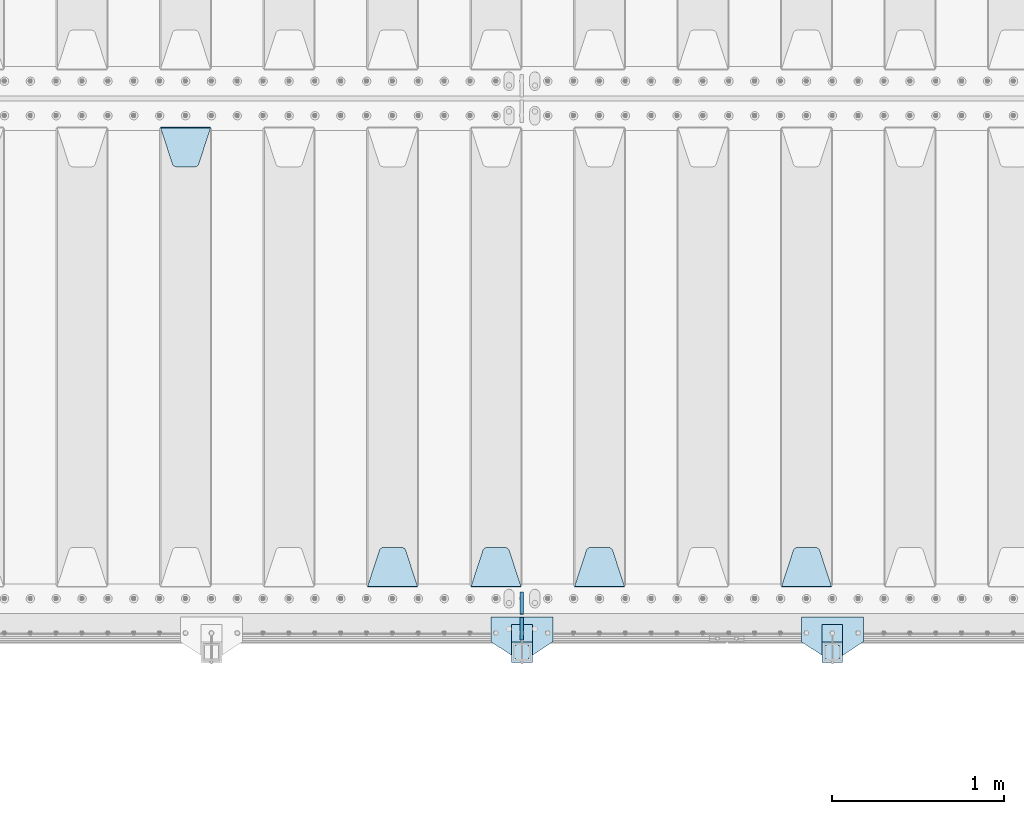
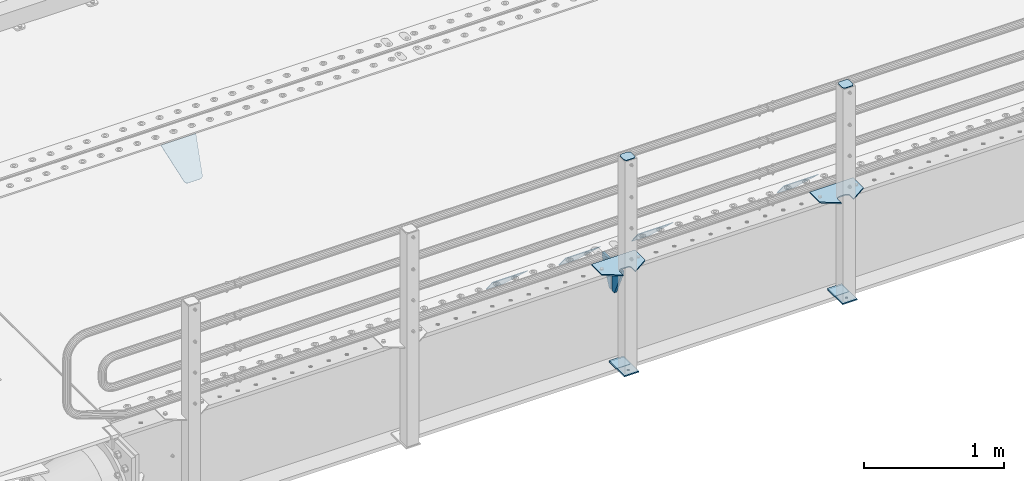
# One storey, part 156 of 193: 15 plates.
"""IFC2X3 building model written with IfcOpenShell, lengths in millimetres."""

from ifc_helpers import new_model, si_unit, frame, origin_with_axes, place, context, subcontext, project, spatial, faceted_brep, material, type_object, element, save


model = new_model("IFC2X3")

# Units and contexts
model_context = context("Model", 3, precision=1e-05, world=origin_with_axes())
body_context = subcontext(model_context, "Body", "Model", "MODEL_VIEW")
ifc_project = project(units=[si_unit("LENGTHUNIT", "METRE", prefix="MILLI"), si_unit("AREAUNIT", "SQUARE_METRE"), si_unit("VOLUMEUNIT", "CUBIC_METRE"), si_unit("MASSUNIT", "GRAM", prefix="KILO"), si_unit("TIMEUNIT", "SECOND"), si_unit("PLANEANGLEUNIT", "RADIAN"), si_unit("SOLIDANGLEUNIT", "STERADIAN"), si_unit("THERMODYNAMICTEMPERATUREUNIT", "DEGREE_CELSIUS"), si_unit("LUMINOUSINTENSITYUNIT", "LUMEN")], contexts=[model_context])

# Site, building, storey
site_placement = place(None, origin_with_axes())
site = spatial("IfcSite", under=ifc_project, at=site_placement, CompositionType="ELEMENT")
building_placement = place(site_placement, origin_with_axes())
building = spatial("IfcBuilding", under=site, at=building_placement, Name="Standard", CompositionType="ELEMENT")
storey_placement = place(building_placement, origin_with_axes())
storey = spatial("IfcBuildingStorey", under=building, at=storey_placement, Name="Undefined", CompositionType="ELEMENT", Elevation=0.0)

# Plates
ifc_material_1 = material(Name="STEEL/S355N")
plate_type_1 = type_object("IfcPlateType", PredefinedType="NOTDEFINED")
plate_1_placement = place(storey_placement, frame((-36505.0, 24168.232233047, -1.76776695296758), z_axis=(0.0, 0.707106781186547, -0.707106781186548), x_axis=(-1.0, 0.0, 0.0)))
element("IfcPlate", 1, at=plate_1_placement, inside=storey, type_object=plate_type_1, material=ifc_material_1, context=body_context, shape_type="Brep", body=[
    faceted_brep([(0.0, -2.5, 0.0), (69.345504679477, -2.50000000000364, 300.171731424831), (69.345504679477, 2.49999999999636, 300.171731424831), (0.0, 2.5, 0.0), (70.9274061199576, -2.50000000000364, 304.897442415397), (70.9274061199576, 2.49999999999636, 304.897442415397), (73.3818627772307, -2.50000000000364, 309.234538108529), (73.3818627772307, 2.49999999999636, 309.234538108529), (76.6187032999551, -2.50000000000728, 313.023683126103), (76.6187032999551, 2.49999999999636, 313.023683126103), (80.5190132704993, -2.50000000000364, 316.125672595372), (80.5190132704993, 2.49999999999636, 316.125672595368), (84.9395038596849, -2.50000000000364, 318.426546230472), (84.9395038596849, 2.49999999999636, 318.426546230476), (89.7177759439219, -2.50000000000364, 319.841774983273), (89.7177759439219, 2.49999999999636, 319.841774983277), (94.678286292652, -2.50000000000364, 320.319366455074), (94.678286292652, 2.49999999999636, 320.319366455074), (195.321713707348, -2.50000000000364, 320.319366455074), (195.321713707348, 2.49999999999636, 320.319366455074), (200.282224056078, -2.50000000000364, 319.841774983273), (200.282224056078, 2.49999999999636, 319.841774983277), (205.060496140315, -2.50000000000364, 318.426546230472), (205.060496140315, 2.49999999999636, 318.426546230472), (209.480986729501, -2.50000000000364, 316.125672595372), (209.480986729501, 2.49999999999636, 316.125672595368), (213.381296700045, -2.50000000000728, 313.023683126103), (213.381296700045, 2.49999999999272, 313.023683126103), (216.618137222769, -2.50000000000364, 309.234538108525), (216.618137222769, 2.49999999999636, 309.234538108522), (219.072593880042, -2.50000000000364, 304.897442415397), (219.072593880042, 2.49999999999636, 304.897442415397), (220.654495320523, -2.50000000000364, 300.171731424831), (220.654495320523, 2.49999999999636, 300.171731424831), (290.0, -2.50000000000364, 0.0), (290.0, 2.49999999999636, 0.0)], [[[0, 1, 2, 3]], [[1, 4, 5, 2]], [[4, 6, 7, 5]], [[6, 8, 9, 7]], [[8, 10, 11, 9]], [[10, 12, 13, 11]], [[12, 14, 15, 13]], [[14, 16, 17, 15]], [[16, 18, 19, 17]], [[18, 20, 21, 19]], [[20, 22, 23, 21]], [[22, 24, 25, 23]], [[24, 26, 27, 25]], [[26, 28, 29, 27]], [[28, 30, 31, 29]], [[30, 32, 33, 31]], [[32, 34, 35, 33]], [[34, 0, 3, 35]], [[5, 7, 9, 11, 13, 15, 17, 19, 21, 23, 25, 27, 29, 31, 33, 35, 3, 2]], [[34, 32, 30, 28, 26, 24, 22, 20, 18, 16, 14, 12, 10, 8, 6, 4, 1, 0]]]),
])
plate_2_placement = place(storey_placement, frame((-37705.0, 24168.232233047, -1.76776695296758), z_axis=(0.0, 0.707106781186547, -0.707106781186548), x_axis=(-1.0, 0.0, 0.0)))
element("IfcPlate", 2, at=plate_2_placement, inside=storey, type_object=plate_type_1, material=ifc_material_1, context=body_context, shape_type="Brep", body=[
    faceted_brep([(0.0, -2.5, 0.0), (69.345504679477, -2.50000000000364, 300.171731424831), (69.345504679477, 2.49999999999636, 300.171731424831), (0.0, 2.5, 0.0), (70.9274061199576, -2.50000000000364, 304.897442415397), (70.9274061199576, 2.49999999999636, 304.897442415397), (73.3818627772307, -2.50000000000364, 309.234538108529), (73.3818627772307, 2.49999999999636, 309.234538108529), (76.6187032999551, -2.50000000000728, 313.023683126103), (76.6187032999551, 2.49999999999636, 313.023683126103), (80.5190132704993, -2.50000000000364, 316.125672595372), (80.5190132704993, 2.49999999999636, 316.125672595368), (84.9395038596849, -2.50000000000364, 318.426546230472), (84.9395038596849, 2.49999999999636, 318.426546230476), (89.7177759439219, -2.50000000000364, 319.841774983273), (89.7177759439219, 2.49999999999636, 319.841774983277), (94.678286292652, -2.50000000000364, 320.319366455074), (94.678286292652, 2.49999999999636, 320.319366455074), (195.321713707348, -2.50000000000364, 320.319366455074), (195.321713707348, 2.49999999999636, 320.319366455074), (200.282224056078, -2.50000000000364, 319.841774983273), (200.282224056078, 2.49999999999636, 319.841774983277), (205.060496140315, -2.50000000000364, 318.426546230472), (205.060496140315, 2.49999999999636, 318.426546230472), (209.480986729501, -2.50000000000364, 316.125672595372), (209.480986729501, 2.49999999999636, 316.125672595368), (213.381296700045, -2.50000000000728, 313.023683126103), (213.381296700045, 2.49999999999272, 313.023683126103), (216.618137222769, -2.50000000000364, 309.234538108525), (216.618137222769, 2.49999999999636, 309.234538108522), (219.072593880042, -2.50000000000364, 304.897442415397), (219.072593880042, 2.49999999999636, 304.897442415397), (220.654495320523, -2.50000000000364, 300.171731424831), (220.654495320523, 2.49999999999636, 300.171731424831), (290.0, -2.50000000000364, 0.0), (290.0, 2.49999999999636, 0.0)], [[[0, 1, 2, 3]], [[1, 4, 5, 2]], [[4, 6, 7, 5]], [[6, 8, 9, 7]], [[8, 10, 11, 9]], [[10, 12, 13, 11]], [[12, 14, 15, 13]], [[14, 16, 17, 15]], [[16, 18, 19, 17]], [[18, 20, 21, 19]], [[20, 22, 23, 21]], [[22, 24, 25, 23]], [[24, 26, 27, 25]], [[26, 28, 29, 27]], [[28, 30, 31, 29]], [[30, 32, 33, 31]], [[32, 34, 35, 33]], [[34, 0, 3, 35]], [[5, 7, 9, 11, 13, 15, 17, 19, 21, 23, 25, 27, 29, 31, 33, 35, 3, 2]], [[34, 32, 30, 28, 26, 24, 22, 20, 18, 16, 14, 12, 10, 8, 6, 4, 1, 0]]]),
])
plate_3_placement = place(storey_placement, frame((-38305.0, 24168.232233047, -1.76776695296758), z_axis=(0.0, 0.707106781186547, -0.707106781186548), x_axis=(-1.0, 0.0, 0.0)))
element("IfcPlate", 3, at=plate_3_placement, inside=storey, type_object=plate_type_1, material=ifc_material_1, context=body_context, shape_type="Brep", body=[
    faceted_brep([(0.0, -2.5, 0.0), (69.345504679477, -2.50000000000364, 300.171731424831), (69.345504679477, 2.49999999999636, 300.171731424831), (0.0, 2.5, 0.0), (70.9274061199576, -2.50000000000364, 304.897442415397), (70.9274061199576, 2.49999999999636, 304.897442415397), (73.3818627772307, -2.50000000000364, 309.234538108529), (73.3818627772307, 2.49999999999636, 309.234538108529), (76.6187032999551, -2.50000000000728, 313.023683126103), (76.6187032999551, 2.49999999999636, 313.023683126103), (80.5190132704993, -2.50000000000364, 316.125672595372), (80.5190132704993, 2.49999999999636, 316.125672595368), (84.9395038596849, -2.50000000000364, 318.426546230472), (84.9395038596849, 2.49999999999636, 318.426546230476), (89.7177759439219, -2.50000000000364, 319.841774983273), (89.7177759439219, 2.49999999999636, 319.841774983277), (94.678286292652, -2.50000000000364, 320.319366455074), (94.678286292652, 2.49999999999636, 320.319366455074), (195.321713707348, -2.50000000000364, 320.319366455074), (195.321713707348, 2.49999999999636, 320.319366455074), (200.282224056078, -2.50000000000364, 319.841774983273), (200.282224056078, 2.49999999999636, 319.841774983277), (205.060496140315, -2.50000000000364, 318.426546230472), (205.060496140315, 2.49999999999636, 318.426546230472), (209.480986729501, -2.50000000000364, 316.125672595372), (209.480986729501, 2.49999999999636, 316.125672595368), (213.381296700045, -2.50000000000728, 313.023683126103), (213.381296700045, 2.49999999999272, 313.023683126103), (216.618137222769, -2.50000000000364, 309.234538108525), (216.618137222769, 2.49999999999636, 309.234538108522), (219.072593880042, -2.50000000000364, 304.897442415397), (219.072593880042, 2.49999999999636, 304.897442415397), (220.654495320523, -2.50000000000364, 300.171731424831), (220.654495320523, 2.49999999999636, 300.171731424831), (290.0, -2.50000000000364, 0.0), (290.0, 2.49999999999636, 0.0)], [[[0, 1, 2, 3]], [[1, 4, 5, 2]], [[4, 6, 7, 5]], [[6, 8, 9, 7]], [[8, 10, 11, 9]], [[10, 12, 13, 11]], [[12, 14, 15, 13]], [[14, 16, 17, 15]], [[16, 18, 19, 17]], [[18, 20, 21, 19]], [[20, 22, 23, 21]], [[22, 24, 25, 23]], [[24, 26, 27, 25]], [[26, 28, 29, 27]], [[28, 30, 31, 29]], [[30, 32, 33, 31]], [[32, 34, 35, 33]], [[34, 0, 3, 35]], [[5, 7, 9, 11, 13, 15, 17, 19, 21, 23, 25, 27, 29, 31, 33, 35, 3, 2]], [[34, 32, 30, 28, 26, 24, 22, 20, 18, 16, 14, 12, 10, 8, 6, 4, 1, 0]]]),
])
plate_4_placement = place(storey_placement, frame((-38905.0, 24168.232233047, -1.76776695296758), z_axis=(0.0, 0.707106781186547, -0.707106781186548), x_axis=(-1.0, 0.0, 0.0)))
element("IfcPlate", 4, at=plate_4_placement, inside=storey, type_object=plate_type_1, material=ifc_material_1, context=body_context, shape_type="Brep", body=[
    faceted_brep([(0.0, -2.5, 0.0), (69.345504679477, -2.50000000000364, 300.171731424831), (69.345504679477, 2.49999999999636, 300.171731424831), (0.0, 2.5, 0.0), (70.9274061199576, -2.50000000000364, 304.897442415397), (70.9274061199576, 2.49999999999636, 304.897442415397), (73.3818627772307, -2.50000000000364, 309.234538108529), (73.3818627772307, 2.49999999999636, 309.234538108529), (76.6187032999551, -2.50000000000728, 313.023683126103), (76.6187032999551, 2.49999999999636, 313.023683126103), (80.5190132704993, -2.50000000000364, 316.125672595372), (80.5190132704993, 2.49999999999636, 316.125672595368), (84.9395038596849, -2.50000000000364, 318.426546230472), (84.9395038596849, 2.49999999999636, 318.426546230476), (89.7177759439219, -2.50000000000364, 319.841774983273), (89.7177759439219, 2.49999999999636, 319.841774983277), (94.678286292652, -2.50000000000364, 320.319366455074), (94.678286292652, 2.49999999999636, 320.319366455074), (195.321713707348, -2.50000000000364, 320.319366455074), (195.321713707348, 2.49999999999636, 320.319366455074), (200.282224056078, -2.50000000000364, 319.841774983273), (200.282224056078, 2.49999999999636, 319.841774983277), (205.060496140315, -2.50000000000364, 318.426546230472), (205.060496140315, 2.49999999999636, 318.426546230472), (209.480986729501, -2.50000000000364, 316.125672595372), (209.480986729501, 2.49999999999636, 316.125672595368), (213.381296700045, -2.50000000000728, 313.023683126103), (213.381296700045, 2.49999999999272, 313.023683126103), (216.618137222769, -2.50000000000364, 309.234538108525), (216.618137222769, 2.49999999999636, 309.234538108522), (219.072593880042, -2.50000000000364, 304.897442415397), (219.072593880042, 2.49999999999636, 304.897442415397), (220.654495320523, -2.50000000000364, 300.171731424831), (220.654495320523, 2.49999999999636, 300.171731424831), (290.0, -2.50000000000364, 0.0), (290.0, 2.49999999999636, 0.0)], [[[0, 1, 2, 3]], [[1, 4, 5, 2]], [[4, 6, 7, 5]], [[6, 8, 9, 7]], [[8, 10, 11, 9]], [[10, 12, 13, 11]], [[12, 14, 15, 13]], [[14, 16, 17, 15]], [[16, 18, 19, 17]], [[18, 20, 21, 19]], [[20, 22, 23, 21]], [[22, 24, 25, 23]], [[24, 26, 27, 25]], [[26, 28, 29, 27]], [[28, 30, 31, 29]], [[30, 32, 33, 31]], [[32, 34, 35, 33]], [[34, 0, 3, 35]], [[5, 7, 9, 11, 13, 15, 17, 19, 21, 23, 25, 27, 29, 31, 33, 35, 3, 2]], [[34, 32, 30, 28, 26, 24, 22, 20, 18, 16, 14, 12, 10, 8, 6, 4, 1, 0]]]),
])
plate_5_placement = place(storey_placement, frame((-40395.0, 26831.767766956, -1.76776695296758), z_axis=(0.0, -0.707106781186547, -0.707106781186548), x_axis=(1.0, 0.0, 0.0)))
element("IfcPlate", 5, at=plate_5_placement, inside=storey, type_object=plate_type_1, material=ifc_material_1, context=body_context, shape_type="Brep", body=[
    faceted_brep([(0.0, -2.5, 0.0), (69.345504679477, -2.50000000000364, 300.171731424831), (69.345504679477, 2.49999999999636, 300.171731424831), (0.0, 2.5, 0.0), (70.9274061199576, -2.50000000000364, 304.897442415397), (70.9274061199576, 2.49999999999636, 304.897442415397), (73.3818627772307, -2.50000000000364, 309.234538108529), (73.3818627772307, 2.49999999999636, 309.234538108529), (76.6187032999551, -2.50000000000728, 313.023683126103), (76.6187032999551, 2.49999999999636, 313.023683126103), (80.5190132704993, -2.50000000000364, 316.125672595372), (80.5190132704993, 2.49999999999636, 316.125672595368), (84.9395038596849, -2.50000000000364, 318.426546230472), (84.9395038596849, 2.49999999999636, 318.426546230476), (89.7177759439219, -2.50000000000364, 319.841774983273), (89.7177759439219, 2.49999999999636, 319.841774983277), (94.678286292652, -2.50000000000364, 320.319366455074), (94.678286292652, 2.49999999999636, 320.319366455074), (195.321713707348, -2.50000000000364, 320.319366455074), (195.321713707348, 2.49999999999636, 320.319366455074), (200.282224056078, -2.50000000000364, 319.841774983273), (200.282224056078, 2.49999999999636, 319.841774983277), (205.060496140315, -2.50000000000364, 318.426546230472), (205.060496140315, 2.49999999999636, 318.426546230472), (209.480986729501, -2.50000000000364, 316.125672595372), (209.480986729501, 2.49999999999636, 316.125672595368), (213.381296700045, -2.50000000000728, 313.023683126103), (213.381296700045, 2.49999999999272, 313.023683126103), (216.618137222769, -2.50000000000364, 309.234538108525), (216.618137222769, 2.49999999999636, 309.234538108522), (219.072593880042, -2.50000000000364, 304.897442415397), (219.072593880042, 2.49999999999636, 304.897442415397), (220.654495320523, -2.50000000000364, 300.171731424831), (220.654495320523, 2.49999999999636, 300.171731424831), (290.0, -2.50000000000364, 0.0), (290.0, 2.49999999999636, 0.0)], [[[0, 1, 2, 3]], [[1, 4, 5, 2]], [[4, 6, 7, 5]], [[6, 8, 9, 7]], [[8, 10, 11, 9]], [[10, 12, 13, 11]], [[12, 14, 15, 13]], [[14, 16, 17, 15]], [[16, 18, 19, 17]], [[18, 20, 21, 19]], [[20, 22, 23, 21]], [[22, 24, 25, 23]], [[24, 26, 27, 25]], [[26, 28, 29, 27]], [[28, 30, 31, 29]], [[30, 32, 33, 31]], [[32, 34, 35, 33]], [[34, 0, 3, 35]], [[5, 7, 9, 11, 13, 15, 17, 19, 21, 23, 25, 27, 29, 31, 33, 35, 3, 2]], [[34, 32, 30, 28, 26, 24, 22, 20, 18, 16, 14, 12, 10, 8, 6, 4, 1, 0]]]),
])
plate_type_2 = type_object("IfcPlateType", PredefinedType="NOTDEFINED")
for number, where, z_axis, x_axis in (
    (6, (-38300.0, 24140.0, -30.0), (0.0, 0.0, -1.0), (0.0, -1.0, 0.0)),
    (7, (-38300.0, 23860.0, -30.0), (0.0, 0.0, -1.0), (0.0, 1.0, 0.0)),
):
    element("IfcPlate", number, at=place(storey_placement, frame(where, z_axis=z_axis, x_axis=x_axis)), inside=storey, type_object=plate_type_2, material=ifc_material_1, context=body_context, shape_type="Brep", body=[
        faceted_brep([(0.0, -10.0, 0.0), (0.0, -10.0, 30.0), (0.0, 10.0, 30.0), (0.0, 10.0, 0.0), (102.0, -10.0, 250.0), (102.0, 10.0, 250.0), (132.0, -10.0, 250.0), (132.0, 10.0, 250.0), (132.0, -10.0, 30.0), (132.0, 10.0, 30.0), (131.544232590368, -10.0, 24.790554669992), (131.544232590368, 10.0, 24.790554669992), (130.190778623579, -10.0, 19.7393957002299), (130.190778623579, 10.0, 19.7393957002299), (127.980762113533, -10.0, 15.0), (127.980762113533, 10.0, 15.0), (124.98133329357, -10.0, 10.7163717094038), (124.98133329357, 10.0, 10.7163717094038), (121.283628290596, -10.0, 7.01866670643062), (121.283628290596, 10.0, 7.01866670643062), (117.0, -10.0, 4.01923788646684), (117.0, 10.0, 4.01923788646684), (112.260604299769, -10.0, 1.80922137642278), (112.260604299769, 10.0, 1.80922137642278), (107.209445330009, -10.0, 0.455767409633722), (107.209445330009, 10.0, 0.455767409633722), (102.0, -10.0, 0.0), (102.0, 10.0, 0.0)], [[[0, 1, 2, 3]], [[1, 4, 5, 2]], [[4, 6, 7, 5]], [[6, 8, 9, 7]], [[8, 10, 11, 9]], [[10, 12, 13, 11]], [[12, 14, 15, 13]], [[14, 16, 17, 15]], [[16, 18, 19, 17]], [[18, 20, 21, 19]], [[20, 22, 23, 21]], [[22, 24, 25, 23]], [[24, 26, 27, 25]], [[26, 0, 3, 27]], [[5, 7, 9, 11, 13, 15, 17, 19, 21, 23, 25, 27, 3, 2]], [[26, 24, 22, 20, 18, 16, 14, 12, 10, 8, 6, 4, 1, 0]]]),
    ])
ifc_material_2 = material(Name="STEEL/S355J2")
plate_type_3 = type_object("IfcPlateType", PredefinedType="NOTDEFINED")
plate_6_placement = place(storey_placement, frame((-36320.0, 23995.0, 5.00000000004911), z_axis=(0.0, -1.0, 0.0), x_axis=(-1.0, 0.0, 0.0)))
element("IfcPlate", 8, at=plate_6_placement, inside=storey, type_object=plate_type_3, material=ifc_material_2, context=body_context, shape_type="Brep", body=[
    faceted_brep([(0.0, -5.0, 0.0), (2.31396552408114e-06, -5.0, 145.0), (2.31396552408114e-06, 5.0, 145.0), (0.0, 5.0, 0.0), (130.0, -5.0, 230.0), (130.0, 5.0, 230.0), (130.0, -5.0, 180.0), (130.0, 5.0, 180.0), (130.48036798992, -5.0, 175.122741949595), (130.48036798992, 5.0, 175.122741949595), (131.903011687216, -5.0, 170.432914190871), (131.903011687216, 5.0, 170.432914190871), (134.213259692435, -5.0, 166.110744174512), (134.213259692435, 5.0, 166.110744174512), (137.322330470335, -5.0, 162.322330470335), (137.322330470335, 5.0, 162.322330470335), (141.110744174512, -5.0, 159.213259692435), (141.110744174512, 5.0, 159.213259692435), (145.432914190871, -5.0, 156.903011687216), (145.432914190871, 5.0, 156.903011687216), (150.122741949595, -5.0, 155.48036798992), (150.122741949595, 5.0, 155.48036798992), (155.0, -5.0, 155.0), (155.0, 5.0, 155.0), (205.0, -5.0, 155.0), (205.0, 5.0, 155.0), (209.877258050405, -5.0, 155.48036798992), (209.877258050405, 5.0, 155.48036798992), (214.567085809129, -5.0, 156.903011687216), (214.567085809129, 5.0, 156.903011687216), (218.889255825488, -5.0, 159.213259692435), (218.889255825488, 5.0, 159.213259692435), (222.677669529665, -5.0, 162.322330470335), (222.677669529665, 5.0, 162.322330470335), (225.786740307565, -5.0, 166.110744174512), (225.786740307565, 5.0, 166.110744174512), (228.096988312784, -5.0, 170.432914190871), (228.096988312784, 5.0, 170.432914190871), (229.51963201008, -5.0, 175.122741949595), (229.51963201008, 5.0, 175.122741949595), (230.0, -5.0, 180.0), (230.0, 5.0, 180.0), (230.0, -5.0, 230.0), (230.0, 5.0, 230.0), (360.0, -5.0, 145.0), (360.0, 5.0, 145.0), (360.0, -5.0, -7.27595761418343e-12), (360.0, 5.0, -7.27595761418343e-12)], [[[0, 1, 2, 3]], [[1, 4, 5, 2]], [[4, 6, 7, 5]], [[6, 8, 9, 7]], [[8, 10, 11, 9]], [[10, 12, 13, 11]], [[12, 14, 15, 13]], [[14, 16, 17, 15]], [[16, 18, 19, 17]], [[18, 20, 21, 19]], [[20, 22, 23, 21]], [[22, 24, 25, 23]], [[24, 26, 27, 25]], [[26, 28, 29, 27]], [[28, 30, 31, 29]], [[30, 32, 33, 31]], [[32, 34, 35, 33]], [[34, 36, 37, 35]], [[36, 38, 39, 37]], [[38, 40, 41, 39]], [[40, 42, 43, 41]], [[42, 44, 45, 43]], [[44, 46, 47, 45]], [[46, 0, 3, 47]], [[5, 7, 9, 11, 13, 15, 17, 19, 21, 23, 25, 27, 29, 31, 33, 35, 37, 39, 41, 43, 45, 47, 3, 2]], [[46, 44, 42, 40, 38, 36, 34, 32, 30, 28, 26, 24, 22, 20, 18, 16, 14, 12, 10, 8, 6, 4, 1, 0]]]),
])
plate_7_placement = place(storey_placement, frame((-38120.0, 23995.0, 5.00000000004911), z_axis=(0.0, -1.0, 0.0), x_axis=(-1.0, 0.0, 0.0)))
element("IfcPlate", 9, at=plate_7_placement, inside=storey, type_object=plate_type_3, material=ifc_material_2, context=body_context, shape_type="Brep", body=[
    faceted_brep([(0.0, -5.0, 0.0), (2.31396552408114e-06, -5.0, 145.0), (2.31396552408114e-06, 5.0, 145.0), (0.0, 5.0, 0.0), (130.0, -5.0, 230.0), (130.0, 5.0, 230.0), (130.0, -5.0, 180.0), (130.0, 5.0, 180.0), (130.48036798992, -5.0, 175.122741949595), (130.48036798992, 5.0, 175.122741949595), (131.903011687216, -5.0, 170.432914190871), (131.903011687216, 5.0, 170.432914190871), (134.213259692435, -5.0, 166.110744174512), (134.213259692435, 5.0, 166.110744174512), (137.322330470335, -5.0, 162.322330470335), (137.322330470335, 5.0, 162.322330470335), (141.110744174512, -5.0, 159.213259692435), (141.110744174512, 5.0, 159.213259692435), (145.432914190871, -5.0, 156.903011687216), (145.432914190871, 5.0, 156.903011687216), (150.122741949595, -5.0, 155.48036798992), (150.122741949595, 5.0, 155.48036798992), (155.0, -5.0, 155.0), (155.0, 5.0, 155.0), (205.0, -5.0, 155.0), (205.0, 5.0, 155.0), (209.877258050405, -5.0, 155.48036798992), (209.877258050405, 5.0, 155.48036798992), (214.567085809129, -5.0, 156.903011687216), (214.567085809129, 5.0, 156.903011687216), (218.889255825488, -5.0, 159.213259692435), (218.889255825488, 5.0, 159.213259692435), (222.677669529665, -5.0, 162.322330470335), (222.677669529665, 5.0, 162.322330470335), (225.786740307565, -5.0, 166.110744174512), (225.786740307565, 5.0, 166.110744174512), (228.096988312784, -5.0, 170.432914190871), (228.096988312784, 5.0, 170.432914190871), (229.51963201008, -5.0, 175.122741949595), (229.51963201008, 5.0, 175.122741949595), (230.0, -5.0, 180.0), (230.0, 5.0, 180.0), (230.0, -5.0, 230.0), (230.0, 5.0, 230.0), (360.0, -5.0, 145.0), (360.0, 5.0, 145.0), (360.0, -5.0, -7.27595761418343e-12), (360.0, 5.0, -7.27595761418343e-12)], [[[0, 1, 2, 3]], [[1, 4, 5, 2]], [[4, 6, 7, 5]], [[6, 8, 9, 7]], [[8, 10, 11, 9]], [[10, 12, 13, 11]], [[12, 14, 15, 13]], [[14, 16, 17, 15]], [[16, 18, 19, 17]], [[18, 20, 21, 19]], [[20, 22, 23, 21]], [[22, 24, 25, 23]], [[24, 26, 27, 25]], [[26, 28, 29, 27]], [[28, 30, 31, 29]], [[30, 32, 33, 31]], [[32, 34, 35, 33]], [[34, 36, 37, 35]], [[36, 38, 39, 37]], [[38, 40, 41, 39]], [[40, 42, 43, 41]], [[42, 44, 45, 43]], [[44, 46, 47, 45]], [[46, 0, 3, 47]], [[5, 7, 9, 11, 13, 15, 17, 19, 21, 23, 25, 27, 29, 31, 33, 35, 37, 39, 41, 43, 45, 47, 3, 2]], [[46, 44, 42, 40, 38, 36, 34, 32, 30, 28, 26, 24, 22, 20, 18, 16, 14, 12, 10, 8, 6, 4, 1, 0]]]),
])
plate_type_4 = type_object("IfcPlateType", PredefinedType="NOTDEFINED")
for number, where, z_axis, x_axis in (
    (10, (-36440.0000000001, 23949.9999999998, -850.000000000002), (0.0, -1.0, 0.0), (-1.0, 0.0, 0.0)),
    (11, (-38240.0000000001, 23949.9999999998, -850.000000000002), (0.0, -1.0, 0.0), (-1.0, 0.0, 0.0)),
):
    element("IfcPlate", number, at=place(storey_placement, frame(where, z_axis=z_axis, x_axis=x_axis)), inside=storey, type_object=plate_type_4, material=ifc_material_2, context=body_context, shape_type="Brep", body=[
        faceted_brep([(53.6360389691836, -5.0, 176.363961030467), (53.6360389691836, 5.0, 176.363961030467), (59.9999999998618, 5.0, 178.999999999789), (59.9999999998618, -5.0, 178.999999999789), (66.3639610305399, 5.0, 176.363961030467), (66.3639610305399, -5.0, 176.363961030467), (68.9999999998618, 5.0, 169.999999999789), (68.9999999998618, -5.0, 169.999999999789), (66.3639610305399, 5.0, 163.636038969111), (66.3639610305399, -5.0, 163.636038969111), (59.9999999998618, 5.0, 160.999999999789), (59.9999999998618, -5.0, 160.999999999789), (53.6360389691836, 5.0, 163.636038969111), (53.6360389691836, -5.0, 163.636038969111), (50.9999999998618, 5.0, 169.999999999789), (50.9999999998618, -5.0, 169.999999999789), (120.0, -5.0, 0.0), (120.0, -5.0, 220.0), (0.0, -5.0, 220.0), (0.0, -5.0, 0.0), (0.0, 5.0, 0.0), (120.0, 5.0, 0.0), (120.0, 5.0, 220.0), (0.0, 5.0, 220.0)], [[[0, 1, 2, 3]], [[3, 2, 4, 5]], [[5, 4, 6, 7]], [[7, 6, 8, 9]], [[9, 8, 10, 11]], [[11, 10, 12, 13]], [[13, 12, 14, 15]], [[15, 14, 1, 0]], [[16, 17, 18, 19], [11, 13, 15, 0, 3, 5, 7, 9]], [[16, 19, 20, 21]], [[17, 16, 21, 22]], [[18, 17, 22, 23]], [[19, 18, 23, 20]], [[22, 21, 20, 23], [2, 1, 14, 12, 10, 8, 6, 4]]]),
    ])
plate_type_5 = type_object("IfcPlateType", PredefinedType="NOTDEFINED")
plate_8_placement = place(storey_placement, frame((-36544.0000000001, 23833.9999999998, 1012.50000000001), z_axis=(0.0, -1.0, 0.0), x_axis=(1.0, 0.0, 0.0)))
element("IfcPlate", 12, at=plate_8_placement, inside=storey, type_object=plate_type_5, material=ifc_material_2, context=body_context, shape_type="Brep", body=[
    faceted_brep([(0.0, -2.5, 19.0), (0.0, -2.5, 69.0), (0.0, 2.5, 69.0), (0.0, 2.5, 19.0), (0.476369668544066, -2.5, 73.2278977451715), (0.476369668544066, 2.5, 73.2278977451715), (1.88159150985302, -2.5, 77.2437910432345), (1.88159150985302, 2.5, 77.2437910432345), (4.14520183310742, -2.5, 80.8463062353148), (4.14520183310742, 2.5, 80.8463062353148), (7.15369376468516, -2.5, 83.8547981668926), (7.15369376468516, 2.5, 83.8547981668926), (10.7562089567655, -2.5, 86.118408490147), (10.7562089567655, 2.5, 86.118408490147), (14.7721022548285, -2.5, 87.5236303314559), (14.7721022548285, 2.5, 87.5236303314559), (19.0, -2.5, 88.0), (19.0, 2.5, 88.0), (69.0, -2.5, 88.0), (69.0, 2.5, 88.0), (73.2278977451715, -2.5, 87.5236303314559), (73.2278977451715, 2.5, 87.5236303314559), (77.2437910432345, -2.5, 86.118408490147), (77.2437910432345, 2.5, 86.118408490147), (80.8463062353148, -2.5, 83.8547981668926), (80.8463062353148, 2.5, 83.8547981668926), (83.8547981668926, -2.5, 80.8463062353148), (83.8547981668926, 2.5, 80.8463062353148), (86.118408490147, -2.5, 77.2437910432345), (86.118408490147, 2.5, 77.2437910432345), (87.5236303314559, -2.5, 73.2278977451715), (87.5236303314559, 2.5, 73.2278977451715), (88.0, -2.5, 69.0), (88.0, 2.5, 69.0), (88.0, -2.5, 19.0), (88.0, 2.5, 19.0), (87.5236303314559, -2.5, 14.7721022548285), (87.5236303314559, 2.5, 14.7721022548285), (86.118408490147, -2.5, 10.7562089567655), (86.118408490147, 2.5, 10.7562089567655), (83.8547981668926, -2.5, 7.15369376468516), (83.8547981668926, 2.5, 7.15369376468516), (80.8463062353148, -2.5, 4.14520183310742), (80.8463062353148, 2.5, 4.14520183310742), (77.2437910432345, -2.5, 1.88159150985302), (77.2437910432345, 2.5, 1.88159150985302), (73.2278977451715, -2.5, 0.476369668544066), (73.2278977451715, 2.5, 0.476369668544066), (69.0, -2.5, 0.0), (69.0, 2.5, 0.0), (19.0, -2.5, 0.0), (19.0, 2.5, 0.0), (14.7721022548285, -2.5, 0.476369668544066), (14.7721022548285, 2.5, 0.476369668544066), (10.7562089567655, -2.5, 1.88159150985302), (10.7562089567655, 2.5, 1.88159150985302), (7.15369376468516, -2.5, 4.14520183310742), (7.15369376468516, 2.5, 4.14520183310742), (4.14520183310742, -2.5, 7.15369376468516), (4.14520183310742, 2.5, 7.15369376468516), (1.88159150985302, -2.5, 10.7562089567655), (1.88159150985302, 2.5, 10.7562089567655), (0.476369668544066, -2.5, 14.7721022548285), (0.476369668544066, 2.5, 14.7721022548285)], [[[0, 1, 2, 3]], [[1, 4, 5, 2]], [[4, 6, 7, 5]], [[6, 8, 9, 7]], [[8, 10, 11, 9]], [[10, 12, 13, 11]], [[12, 14, 15, 13]], [[14, 16, 17, 15]], [[16, 18, 19, 17]], [[18, 20, 21, 19]], [[20, 22, 23, 21]], [[22, 24, 25, 23]], [[24, 26, 27, 25]], [[26, 28, 29, 27]], [[28, 30, 31, 29]], [[30, 32, 33, 31]], [[32, 34, 35, 33]], [[34, 36, 37, 35]], [[36, 38, 39, 37]], [[38, 40, 41, 39]], [[40, 42, 43, 41]], [[42, 44, 45, 43]], [[44, 46, 47, 45]], [[46, 48, 49, 47]], [[48, 50, 51, 49]], [[50, 52, 53, 51]], [[52, 54, 55, 53]], [[54, 56, 57, 55]], [[56, 58, 59, 57]], [[58, 60, 61, 59]], [[60, 62, 63, 61]], [[62, 0, 3, 63]], [[5, 7, 9, 11, 13, 15, 17, 19, 21, 23, 25, 27, 29, 31, 33, 35, 37, 39, 41, 43, 45, 47, 49, 51, 53, 55, 57, 59, 61, 63, 3, 2]], [[62, 60, 58, 56, 54, 52, 50, 48, 46, 44, 42, 40, 38, 36, 34, 32, 30, 28, 26, 24, 22, 20, 18, 16, 14, 12, 10, 8, 6, 4, 1, 0]]]),
])
plate_9_placement = place(storey_placement, frame((-38344.0000000001, 23833.9999999998, 1012.50000000001), z_axis=(0.0, -1.0, 0.0), x_axis=(1.0, 0.0, 0.0)))
element("IfcPlate", 13, at=plate_9_placement, inside=storey, type_object=plate_type_5, material=ifc_material_2, context=body_context, shape_type="Brep", body=[
    faceted_brep([(0.0, -2.5, 19.0), (0.0, -2.5, 69.0), (0.0, 2.5, 69.0), (0.0, 2.5, 19.0), (0.476369668544066, -2.5, 73.2278977451715), (0.476369668544066, 2.5, 73.2278977451715), (1.88159150985302, -2.5, 77.2437910432345), (1.88159150985302, 2.5, 77.2437910432345), (4.14520183310742, -2.5, 80.8463062353148), (4.14520183310742, 2.5, 80.8463062353148), (7.15369376468516, -2.5, 83.8547981668926), (7.15369376468516, 2.5, 83.8547981668926), (10.7562089567655, -2.5, 86.118408490147), (10.7562089567655, 2.5, 86.118408490147), (14.7721022548285, -2.5, 87.5236303314559), (14.7721022548285, 2.5, 87.5236303314559), (19.0, -2.5, 88.0), (19.0, 2.5, 88.0), (69.0, -2.5, 88.0), (69.0, 2.5, 88.0), (73.2278977451715, -2.5, 87.5236303314559), (73.2278977451715, 2.5, 87.5236303314559), (77.2437910432345, -2.5, 86.118408490147), (77.2437910432345, 2.5, 86.118408490147), (80.8463062353148, -2.5, 83.8547981668926), (80.8463062353148, 2.5, 83.8547981668926), (83.8547981668926, -2.5, 80.8463062353148), (83.8547981668926, 2.5, 80.8463062353148), (86.118408490147, -2.5, 77.2437910432345), (86.118408490147, 2.5, 77.2437910432345), (87.5236303314559, -2.5, 73.2278977451715), (87.5236303314559, 2.5, 73.2278977451715), (88.0, -2.5, 69.0), (88.0, 2.5, 69.0), (88.0, -2.5, 19.0), (88.0, 2.5, 19.0), (87.5236303314559, -2.5, 14.7721022548285), (87.5236303314559, 2.5, 14.7721022548285), (86.118408490147, -2.5, 10.7562089567655), (86.118408490147, 2.5, 10.7562089567655), (83.8547981668926, -2.5, 7.15369376468516), (83.8547981668926, 2.5, 7.15369376468516), (80.8463062353148, -2.5, 4.14520183310742), (80.8463062353148, 2.5, 4.14520183310742), (77.2437910432345, -2.5, 1.88159150985302), (77.2437910432345, 2.5, 1.88159150985302), (73.2278977451715, -2.5, 0.476369668544066), (73.2278977451715, 2.5, 0.476369668544066), (69.0, -2.5, 0.0), (69.0, 2.5, 0.0), (19.0, -2.5, 0.0), (19.0, 2.5, 0.0), (14.7721022548285, -2.5, 0.476369668544066), (14.7721022548285, 2.5, 0.476369668544066), (10.7562089567655, -2.5, 1.88159150985302), (10.7562089567655, 2.5, 1.88159150985302), (7.15369376468516, -2.5, 4.14520183310742), (7.15369376468516, 2.5, 4.14520183310742), (4.14520183310742, -2.5, 7.15369376468516), (4.14520183310742, 2.5, 7.15369376468516), (1.88159150985302, -2.5, 10.7562089567655), (1.88159150985302, 2.5, 10.7562089567655), (0.476369668544066, -2.5, 14.7721022548285), (0.476369668544066, 2.5, 14.7721022548285)], [[[0, 1, 2, 3]], [[1, 4, 5, 2]], [[4, 6, 7, 5]], [[6, 8, 9, 7]], [[8, 10, 11, 9]], [[10, 12, 13, 11]], [[12, 14, 15, 13]], [[14, 16, 17, 15]], [[16, 18, 19, 17]], [[18, 20, 21, 19]], [[20, 22, 23, 21]], [[22, 24, 25, 23]], [[24, 26, 27, 25]], [[26, 28, 29, 27]], [[28, 30, 31, 29]], [[30, 32, 33, 31]], [[32, 34, 35, 33]], [[34, 36, 37, 35]], [[36, 38, 39, 37]], [[38, 40, 41, 39]], [[40, 42, 43, 41]], [[42, 44, 45, 43]], [[44, 46, 47, 45]], [[46, 48, 49, 47]], [[48, 50, 51, 49]], [[50, 52, 53, 51]], [[52, 54, 55, 53]], [[54, 56, 57, 55]], [[56, 58, 59, 57]], [[58, 60, 61, 59]], [[60, 62, 63, 61]], [[62, 0, 3, 63]], [[5, 7, 9, 11, 13, 15, 17, 19, 21, 23, 25, 27, 29, 31, 33, 35, 37, 39, 41, 43, 45, 47, 49, 51, 53, 55, 57, 59, 61, 63, 3, 2]], [[62, 60, 58, 56, 54, 52, 50, 48, 46, 44, 42, 40, 38, 36, 34, 32, 30, 28, 26, 24, 22, 20, 18, 16, 14, 12, 10, 8, 6, 4, 1, 0]]]),
])
plate_type_6 = type_object("IfcPlateType", PredefinedType="NOTDEFINED")
for number, where, z_axis, x_axis in (
    (14, (-36440.0000000001, 23949.9999999998, -857.500000000002), (0.0, -1.0, 0.0), (-1.0, 0.0, 0.0)),
    (15, (-38240.0000000001, 23949.9999999998, -857.500000000002), (0.0, -1.0, 0.0), (-1.0, 0.0, 0.0)),
):
    element("IfcPlate", number, at=place(storey_placement, frame(where, z_axis=z_axis, x_axis=x_axis)), inside=storey, type_object=plate_type_6, material=ifc_material_2, context=body_context, shape_type="Brep", body=[
        faceted_brep([(0.0, -2.5, 0.0), (0.0, -2.5, 100.0), (0.0, 2.5, 100.0), (0.0, 2.5, 0.0), (120.0, -2.5, 100.0), (120.0, 2.5, 100.0), (120.0, -2.5, 0.0), (120.0, 2.5, 0.0)], [[[0, 1, 2, 3]], [[1, 4, 5, 2]], [[4, 6, 7, 5]], [[6, 0, 3, 7]], [[5, 7, 3, 2]], [[6, 4, 1, 0]]]),
    ])

save(model, "model.ifc")
